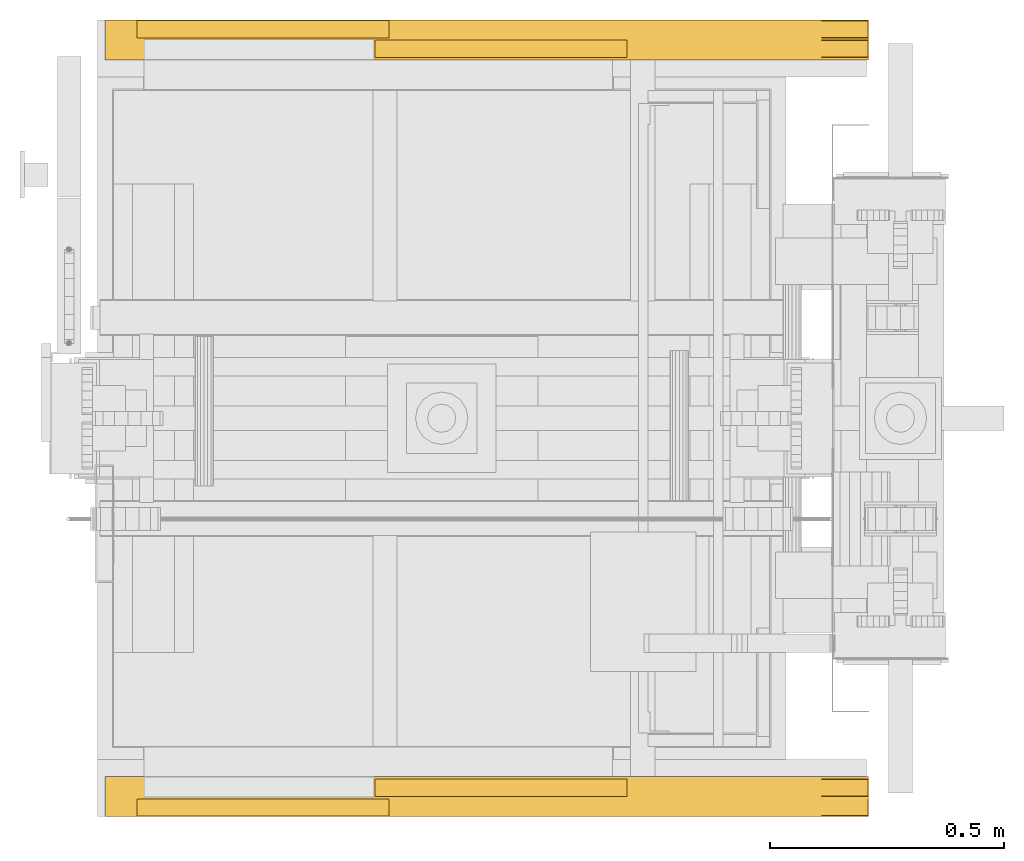
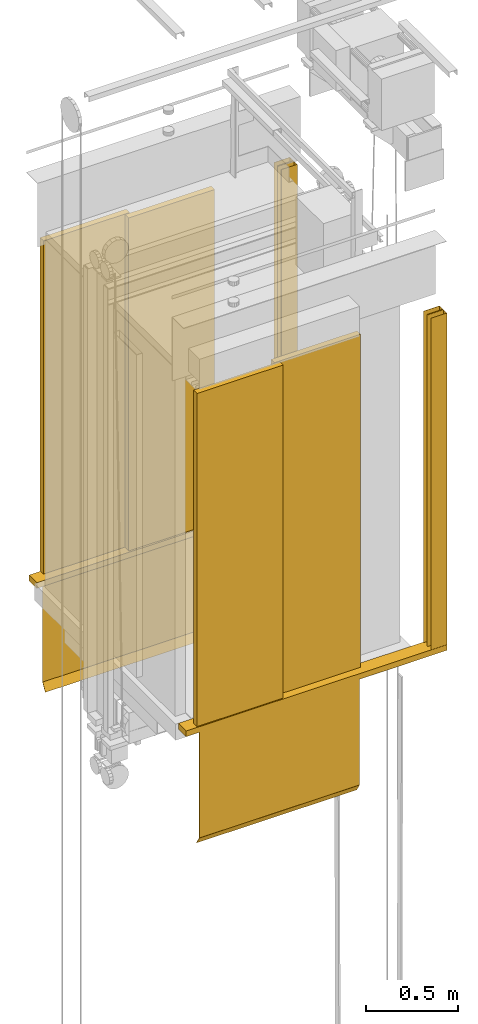
# One storey, part 2 of 13: 2 doors.
"""IFC4 building model written with IfcOpenShell, lengths in millimetres."""

from ifc_helpers import new_model, entity, si_unit, converted_unit, frame, origin_with_axes, place, context, subcontext, project, spatial, faceted_brep, element, save


model = new_model("IFC4")

# Units and contexts
context_of_model = context(None, 3, precision=0.01, world=origin_with_axes())
sub_context_1 = subcontext(context_of_model, None, None, "MODEL_VIEW")
sub_context_2 = subcontext(context_of_model, None, None, "MODEL_VIEW")
ifc_project = project(units=[converted_unit("PLANEANGLEUNIT", "degree", entity("IfcPlaneAngleMeasure", 0.017453292519943), si_unit("PLANEANGLEUNIT", "RADIAN"), dimensions=[0, 0, 0, 0, 0, 0, 0]), si_unit("LENGTHUNIT", "METRE", prefix="MILLI"), si_unit("MASSUNIT", "GRAM", prefix="KILO"), converted_unit("TIMEUNIT", "year", entity("IfcTimeMeasure", 31557600.0), si_unit("TIMEUNIT", "SECOND"), dimensions=[0, 0, 1, 0, 0, 0, 0]), si_unit("THERMODYNAMICTEMPERATUREUNIT", "DEGREE_CELSIUS"), si_unit("AREAUNIT", "SQUARE_METRE"), si_unit("FORCEUNIT", "NEWTON"), si_unit("VOLUMEUNIT", "CUBIC_METRE"), si_unit("PRESSUREUNIT", "PASCAL"), si_unit("SOLIDANGLEUNIT", "STERADIAN")], contexts=[context_of_model])

# Site, building, storey
site = spatial("IfcSite", under=ifc_project)
building = spatial("IfcBuilding", under=site, Name="Document")
placement = place(None, origin_with_axes())
storey_placement = place(placement, frame((0.0, 0.0, -26400.0), z_axis=(0.0, 0.0, 1.0), x_axis=(1.0, 0.0, 0.0)))
storey = spatial("IfcBuildingStorey", under=building, at=storey_placement, Name="Z -26400", Elevation=-26400.0)

# Doors
door_1_placement = place(storey_placement, frame((765.0, 175.0, 31219.0), z_axis=(0.0, 0.0, 1.0), x_axis=(1.0, 0.0, 0.0)))
element("IfcDoor", 1, at=door_1_placement, inside=storey, ObjectType="35 TR2", OperationType="SLIDING_TO_RIGHT", OverallHeight=2200.0, OverallWidth=1000.0, context=sub_context_1, shape_type="Brep", body=[
    faceted_brep([(-500.0, 32.78623962402344, -784.228515625), (500.0, 32.78623962402344, -784.228515625), (500.0, 30.213760375976562, -785.771484375), (-500.0, 30.213760375976562, -785.771484375), (-500.0, 0.213760375976562, -735.771484375), (-500.0, 1.5, -735.0), (-500.0, 0.0, -735.0), (-500.0, 0.0, -37.0), (-500.0, 3.0, -37.0), (-500.0, 3.0, -734.583984375), (500.0, 0.213760375976562, -735.771484375), (-500.0, 2.786239624023438, -734.228515625), (500.0, 2.786239624023438, -734.228515625), (500.0, 3.0, -734.583984375), (500.0, 1.5, -735.0), (-500.0, 3.0, -735.0), (500.0, 3.0, -735.0), (500.0, 0.0, -735.0), (500.0, 0.0, -37.0), (1046.0, 0.0, -37.0), (1046.0, 0.0, 0.0), (-583.5, 0.0, 0.0), (-583.5, 0.0, -37.0), (500.0, 3.0, -37.0), (-583.5, 85.0, 0.0), (-583.5, 85.0, -37.0), (1046.0, 85.0, -37.0), (1046.0, 85.0, 0.0)], [[[0, 1, 2, 3]], [[4, 5, 6, 7, 8, 9, 0, 3]], [[2, 10, 4, 3]], [[9, 11, 12, 13, 1, 0]], [[10, 14, 12, 11, 5, 4]], [[5, 15, 16, 14, 17, 6]], [[17, 18, 19, 20, 21, 22, 7, 6]], [[11, 9, 15, 5]], [[9, 8, 23, 13, 16, 15]], [[21, 24, 25, 22]], [[25, 26, 19, 18, 23, 8, 7, 22]], [[20, 27, 24, 21]], [[24, 27, 26, 25]], [[1, 13, 23, 18, 17, 14, 10, 2]], [[16, 13, 12, 14]], [[26, 27, 20, 19]]]),
    faceted_brep([(-514.9499969482422, 38.0, 5.0), (22.45001220703125, 38.0, 5.0), (22.45001220703125, 1.0, 5.0), (-514.9499969482422, 1.0, 5.0), (-514.9499969482422, 1.0, 2205.0), (-514.9499969482422, 38.0, 2205.0), (22.45001220703125, 1.0, 2205.0), (22.45001220703125, 38.0, 2205.0)], [[[0, 1, 2, 3]], [[4, 5, 0, 3]], [[2, 6, 4, 3]], [[5, 7, 1, 0]], [[1, 7, 6, 2]], [[6, 7, 5, 4]]]),
    faceted_brep([(-7.45001220703125, 80.0, 5.0), (529.949951171875, 80.0, 5.0), (529.949951171875, 43.0, 5.0), (-7.45001220703125, 43.0, 5.0), (-7.45001220703125, 43.0, 2205.0), (-7.45001220703125, 80.0, 2205.0), (529.949951171875, 43.0, 2205.0), (529.949951171875, 80.0, 2205.0)], [[[0, 1, 2, 3]], [[4, 5, 0, 3]], [[2, 6, 4, 3]], [[5, 7, 1, 0]], [[1, 7, 6, 2]], [[6, 7, 5, 4]]]),
    faceted_brep([(946.0, 2.0, 0.0), (1045.0, 2.0, 0.0), (1045.0, 37.0, 0.0), (946.0, 37.0, 0.0), (946.0, 38.0, 0.0), (1046.0, 38.0, 0.0), (1046.0, 1.0, 0.0), (946.0, 1.0, 0.0), (946.0, 1.0, 2190.0), (946.0, 2.0, 2190.0), (1046.0, 1.0, 2190.0), (1045.0, 2.0, 2190.0), (946.0, 37.0, 2190.0), (946.0, 38.0, 2190.0), (1045.0, 37.0, 2190.0), (1046.0, 38.0, 2190.0)], [[[0, 1, 2, 3, 4, 5, 6, 7]], [[8, 9, 0, 7]], [[6, 10, 8, 7]], [[9, 11, 1, 0]], [[12, 13, 4, 3]], [[2, 14, 12, 3]], [[13, 15, 5, 4]], [[11, 14, 2, 1]], [[5, 15, 10, 6]], [[10, 15, 13, 12, 14, 11, 9, 8]]]),
    faceted_brep([(946.0, 44.0, 0.0), (1045.0, 44.0, 0.0), (1045.0, 79.0, 0.0), (946.0, 79.0, 0.0), (946.0, 80.0, 0.0), (1046.0, 80.0, 0.0), (1046.0, 43.0, 0.0), (946.0, 43.0, 0.0), (946.0, 43.0, 2190.0), (946.0, 44.0, 2190.0), (1046.0, 43.0, 2190.0), (1045.0, 44.0, 2190.0), (946.0, 79.0, 2190.0), (946.0, 80.0, 2190.0), (1045.0, 79.0, 2190.0), (1046.0, 80.0, 2190.0)], [[[0, 1, 2, 3, 4, 5, 6, 7]], [[8, 9, 0, 7]], [[6, 10, 8, 7]], [[9, 11, 1, 0]], [[12, 13, 4, 3]], [[2, 14, 12, 3]], [[13, 15, 5, 4]], [[11, 14, 2, 1]], [[5, 15, 10, 6]], [[10, 15, 13, 12, 14, 11, 9, 8]]]),
])
door_2_placement = place(storey_placement, frame((765.0, 1875.0, 31219.0), z_axis=(0.0, 0.0, 1.0), x_axis=(-1.0, 0.0, 0.0)))
element("IfcDoor", 2, at=door_2_placement, inside=storey, ObjectType="35 TL2", OperationType="SLIDING_TO_LEFT", OverallHeight=2200.0, OverallWidth=1000.0, context=sub_context_2, shape_type="Brep", body=[
    faceted_brep([(7.45001220703125, 43.0, 5.0), (-529.949951171875, 43.0, 5.0), (-529.949951171875, 80.0, 5.0), (7.45001220703125, 80.0, 5.0), (7.45001220703125, 80.0, 2205.0), (7.45001220703125, 43.0, 2205.0), (-529.949951171875, 80.0, 2205.0), (-529.949951171875, 43.0, 2205.0)], [[[0, 1, 2, 3]], [[4, 5, 0, 3]], [[2, 6, 4, 3]], [[5, 7, 1, 0]], [[1, 7, 6, 2]], [[6, 7, 5, 4]]]),
    faceted_brep([(514.9499969482422, 1.0, 5.0), (-22.45001220703125, 1.0, 5.0), (-22.45001220703125, 38.0, 5.0), (514.9499969482422, 38.0, 5.0), (514.9499969482422, 38.0, 2205.0), (514.9499969482422, 1.0, 2205.0), (-22.45001220703125, 38.0, 2205.0), (-22.45001220703125, 1.0, 2205.0)], [[[0, 1, 2, 3]], [[4, 5, 0, 3]], [[2, 6, 4, 3]], [[5, 7, 1, 0]], [[1, 7, 6, 2]], [[6, 7, 5, 4]]]),
    faceted_brep([(500.0, 30.2137451171875, -785.771484375), (-500.0, 30.2137451171875, -785.771484375), (-500.0, 32.7862548828125, -784.228515625), (500.0, 32.7862548828125, -784.228515625), (500.0, 3.0, -734.583984375), (500.0, 3.0, -37.0), (500.0, 0.0, -37.0), (500.0, 0.0, -735.0), (500.0, 1.5, -735.0), (500.0, 0.2137451171875, -735.771484375), (-500.0, 3.0, -734.583984375), (-500.0, 2.7862548828125, -734.228515625), (500.0, 2.7862548828125, -734.228515625), (-500.0, 0.2137451171875, -735.771484375), (500.0, 3.0, -735.0), (-500.0, 3.0, -735.0), (-500.0, 3.0, -37.0), (-500.0, 0.0, -735.0), (-500.0, 1.5, -735.0), (583.5, 0.0, -37.0), (583.5, 0.0, 0.0), (-1046.0, 0.0, 0.0), (-1046.0, 0.0, -37.0), (-500.0, 0.0, -37.0), (583.5, 85.0, 0.0), (583.5, 85.0, -37.0), (-1046.0, 85.0, -37.0), (-1046.0, 85.0, 0.0)], [[[0, 1, 2, 3]], [[4, 5, 6, 7, 8, 9, 0, 3]], [[2, 10, 11, 12, 4, 3]], [[9, 13, 1, 0]], [[4, 12, 8, 14]], [[15, 10, 16, 5, 4, 14]], [[8, 7, 17, 18, 15, 14]], [[11, 18, 13, 9, 8, 12]], [[6, 19, 20, 21, 22, 23, 17, 7]], [[24, 20, 19, 25]], [[26, 27, 24, 25]], [[19, 6, 5, 16, 23, 22, 26, 25]], [[27, 21, 20, 24]], [[1, 13, 18, 17, 23, 16, 10, 2]], [[18, 11, 10, 15]], [[22, 21, 27, 26]]]),
    faceted_brep([(-946.0, 79.0, 0.0), (-1045.0, 79.0, 0.0), (-1045.0, 44.0, 0.0), (-946.0, 44.0, 0.0), (-946.0, 43.0, 0.0), (-1046.0, 43.0, 0.0), (-1046.0, 80.0, 0.0), (-946.0, 80.0, 0.0), (-946.0, 80.0, 2190.0), (-946.0, 79.0, 2190.0), (-1046.0, 80.0, 2190.0), (-1045.0, 79.0, 2190.0), (-946.0, 44.0, 2190.0), (-946.0, 43.0, 2190.0), (-1045.0, 44.0, 2190.0), (-1046.0, 43.0, 2190.0)], [[[0, 1, 2, 3, 4, 5, 6, 7]], [[8, 9, 0, 7]], [[6, 10, 8, 7]], [[9, 11, 1, 0]], [[12, 13, 4, 3]], [[2, 14, 12, 3]], [[13, 15, 5, 4]], [[11, 14, 2, 1]], [[5, 15, 10, 6]], [[10, 15, 13, 12, 14, 11, 9, 8]]]),
    faceted_brep([(-946.0, 37.0, 0.0), (-1045.0, 37.0, 0.0), (-1045.0, 2.0, 0.0), (-946.0, 2.0, 0.0), (-946.0, 1.0, 0.0), (-1046.0, 1.0, 0.0), (-1046.0, 38.0, 0.0), (-946.0, 38.0, 0.0), (-946.0, 38.0, 2190.0), (-946.0, 37.0, 2190.0), (-1046.0, 38.0, 2190.0), (-1045.0, 37.0, 2190.0), (-946.0, 2.0, 2190.0), (-946.0, 1.0, 2190.0), (-1045.0, 2.0, 2190.0), (-1046.0, 1.0, 2190.0)], [[[0, 1, 2, 3, 4, 5, 6, 7]], [[8, 9, 0, 7]], [[6, 10, 8, 7]], [[9, 11, 1, 0]], [[12, 13, 4, 3]], [[2, 14, 12, 3]], [[13, 15, 5, 4]], [[11, 14, 2, 1]], [[5, 15, 10, 6]], [[10, 15, 13, 12, 14, 11, 9, 8]]]),
])

save(model, "model.ifc")
